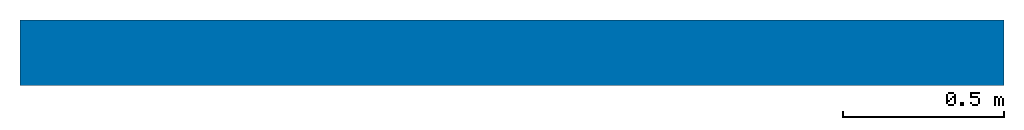
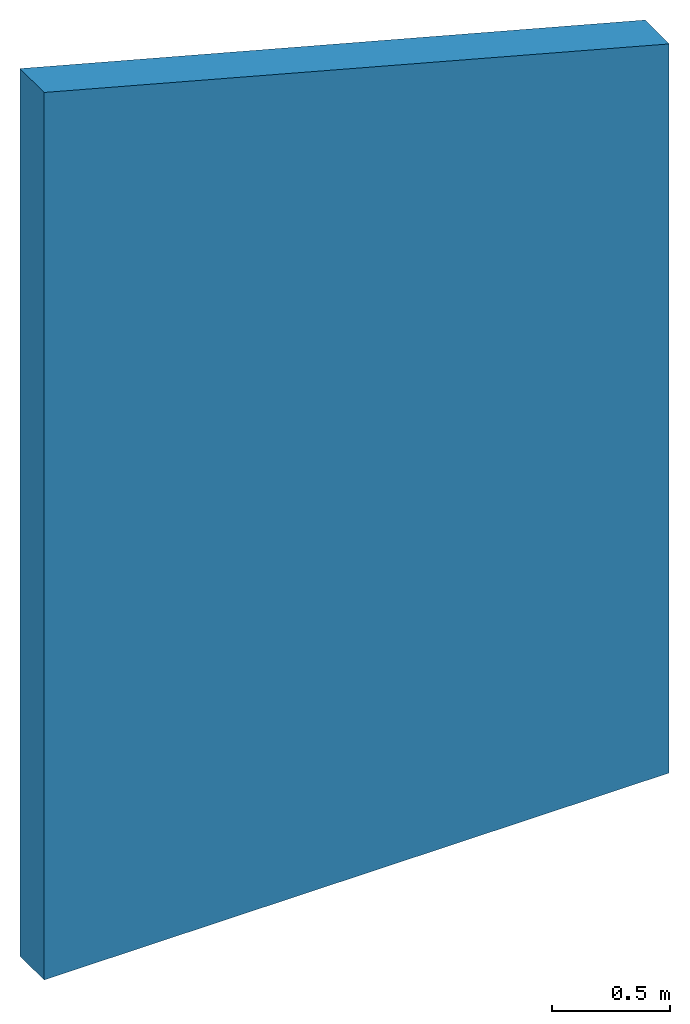
# One storey: 1 wall.
"""IFC4 building model written with IfcOpenShell, lengths in feet."""

from ifc_helpers import new_model, entity, si_unit, converted_unit, derived_unit, direction, frame, frame_2d, origin, place, context, subcontext, project, spatial, polyline, rectangle, extrude, clip, bounded_halfspace, material, layer, layer_set, layer_usage, type_object, element, save


model = new_model("IFC4")

# Units and contexts
model_context = context("Model", 3, precision=0.0001, world=origin(), true_north=direction((6.12303176911189e-17, 1.0)))
body_context = subcontext(model_context, "Body", "Model", "MODEL_VIEW")
ifc_project = project(units=[converted_unit("LENGTHUNIT", "FOOT", entity("IfcRatioMeasure", 0.3048), si_unit("LENGTHUNIT", "METRE"), dimensions=[1, 0, 0, 0, 0, 0, 0]), converted_unit("AREAUNIT", "SQUARE FOOT", entity("IfcRatioMeasure", 0.09290304), si_unit("AREAUNIT", "SQUARE_METRE"), dimensions=[2, 0, 0, 0, 0, 0, 0]), converted_unit("VOLUMEUNIT", "CUBIC FOOT", entity("IfcRatioMeasure", 0.028316846592), si_unit("VOLUMEUNIT", "CUBIC_METRE"), dimensions=[3, 0, 0, 0, 0, 0, 0]), converted_unit("PLANEANGLEUNIT", "DEGREE", entity("IfcRatioMeasure", 0.0174532925199433), si_unit("PLANEANGLEUNIT", "RADIAN"), dimensions=[0, 0, 0, 0, 0, 0, 0]), si_unit("MASSUNIT", "GRAM", prefix="KILO"), derived_unit("MASSDENSITYUNIT", [(si_unit("MASSUNIT", "GRAM", prefix="KILO"), 1), (si_unit("LENGTHUNIT", "METRE"), -3)]), derived_unit("MOMENTOFINERTIAUNIT", [(si_unit("LENGTHUNIT", "METRE"), 4)]), si_unit("TIMEUNIT", "SECOND"), si_unit("FREQUENCYUNIT", "HERTZ"), si_unit("THERMODYNAMICTEMPERATUREUNIT", "DEGREE_CELSIUS"), derived_unit("THERMALTRANSMITTANCEUNIT", [(si_unit("MASSUNIT", "GRAM", prefix="KILO"), 1), (si_unit("THERMODYNAMICTEMPERATUREUNIT", "KELVIN"), -1), (si_unit("TIMEUNIT", "SECOND"), -3)]), derived_unit("VOLUMETRICFLOWRATEUNIT", [(si_unit("LENGTHUNIT", "METRE"), 3), (si_unit("TIMEUNIT", "SECOND"), -1)]), si_unit("ELECTRICCURRENTUNIT", "AMPERE"), si_unit("ELECTRICVOLTAGEUNIT", "VOLT"), si_unit("POWERUNIT", "WATT"), si_unit("FORCEUNIT", "NEWTON"), si_unit("ILLUMINANCEUNIT", "LUX"), si_unit("LUMINOUSFLUXUNIT", "LUMEN"), si_unit("LUMINOUSINTENSITYUNIT", "CANDELA"), derived_unit("USERDEFINED", [(si_unit("MASSUNIT", "GRAM", prefix="KILO"), -1), (si_unit("LENGTHUNIT", "METRE"), -2), (si_unit("TIMEUNIT", "SECOND"), 3), (si_unit("LUMINOUSFLUXUNIT", "LUMEN"), 1)]), derived_unit("LINEARVELOCITYUNIT", [(si_unit("LENGTHUNIT", "METRE"), 1), (si_unit("TIMEUNIT", "SECOND"), -1)]), si_unit("PRESSUREUNIT", "PASCAL"), derived_unit("USERDEFINED", [(si_unit("LENGTHUNIT", "METRE"), -2), (si_unit("MASSUNIT", "GRAM", prefix="KILO"), 1), (si_unit("TIMEUNIT", "SECOND"), -2)]), derived_unit("LINEARFORCEUNIT", [(si_unit("MASSUNIT", "GRAM", prefix="KILO"), 1), (si_unit("LENGTHUNIT", "METRE"), 1), (si_unit("TIMEUNIT", "SECOND"), -2), (si_unit("LENGTHUNIT", "METRE"), -1)]), derived_unit("PLANARFORCEUNIT", [(si_unit("MASSUNIT", "GRAM", prefix="KILO"), 1), (si_unit("LENGTHUNIT", "METRE"), 1), (si_unit("TIMEUNIT", "SECOND"), -2), (si_unit("LENGTHUNIT", "METRE"), -2)])], contexts=[model_context])

# Site, building, storey
site_placement = place(None, origin())
site = spatial("IfcSite", under=ifc_project, at=site_placement, CompositionType="ELEMENT")
building_placement = place(site_placement, origin())
building = spatial("IfcBuilding", under=site, at=building_placement, CompositionType="ELEMENT")
storey_placement = place(building_placement, origin())
storey = spatial("IfcBuildingStorey", under=building, at=storey_placement, Name="Level 1", CompositionType="ELEMENT", Elevation=0.0)

# Wall
ifc_material_1 = material(Name="1", Category="Materials")
ifc_layer_1 = layer(ifc_material_1, 0.333333333333333, Name="1", Category="Materials")
ifc_material_2 = material(Name="2", Category="Materials")
ifc_layer_2 = layer(ifc_material_2, 0.333333333333333, Name="2", Category="Materials")
ifc_layer_set = layer_set([ifc_layer_1, ifc_layer_2])
ifc_layer_usage = layer_usage(ifc_layer_set, "AXIS2", "NEGATIVE", 0.333333333333333)
wall_type = type_object("IfcWallType", PredefinedType="STANDARD", material=ifc_layer_set)
wall_placement = place(storey_placement, origin())
element("IfcWall", 1, at=wall_placement, inside=storey, type_object=wall_type, material=ifc_layer_usage, PredefinedType="NOTDEFINED", context=body_context, shape_type="Clipping", body=[
    clip(extrude(rectangle(XDim=10.0, YDim=0.666666666666667, at=frame_2d((5.0, 0.0), x_axis=(-1.0, 0.0))), origin(), (0.0, 0.0, 1.0), 15.009056402861), bounded_halfspace(frame((0.0, -0.333333333333333, 15.009056402861), z_axis=(0.25881904510252, 0.0, 0.965925826289069), x_axis=(0.0, 1.0, 0.0)), False, frame((0.0, -0.333333333333333, 15.009056402861)), polyline([(0.0, 0.0), (10.0, 0.0), (10.0, 0.666666666666667), (0.0, 0.666666666666667), (0.0, 0.0)]))),
])

save(model, "model.ifc")
